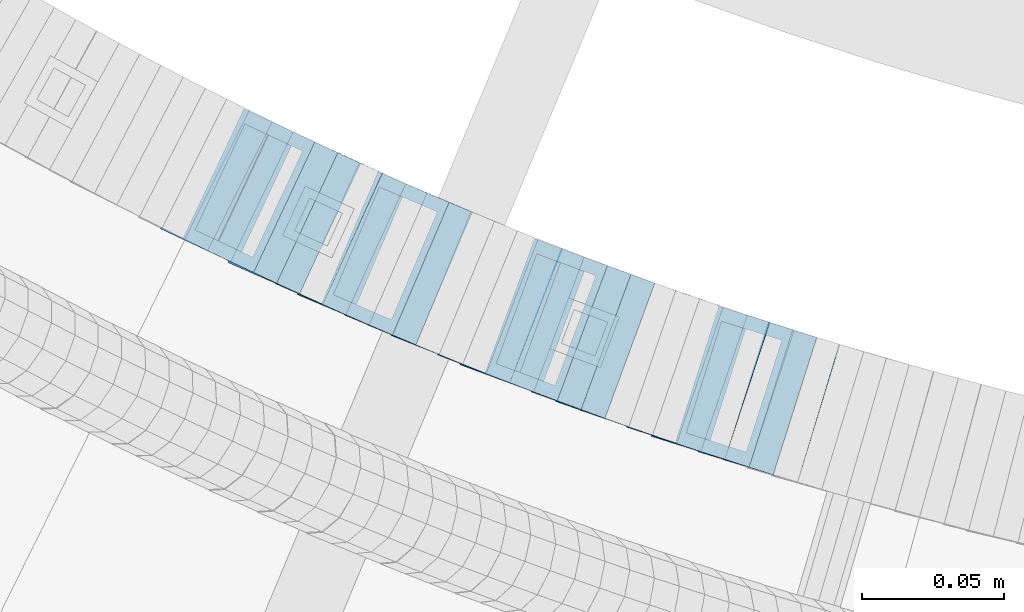
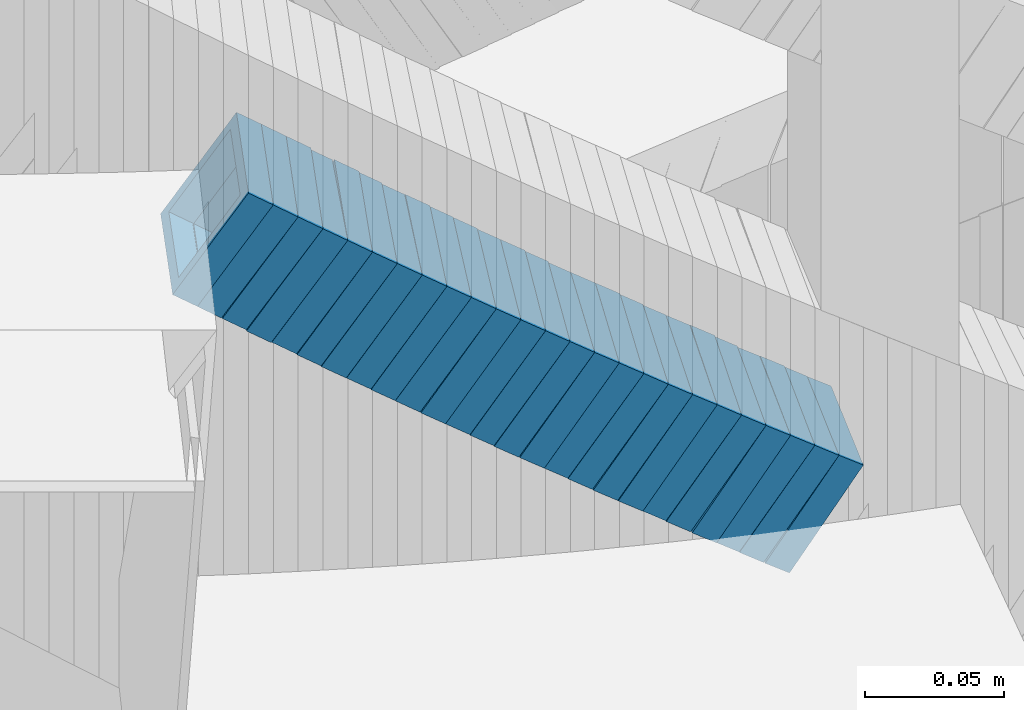
# One storey, part 695 of 975: 25 members.
"""IFC2X3 building model written with IfcOpenShell, lengths in millimetres."""

import ifcopenshell
import ifcopenshell.guid

model = None  # the IFC model being written
_history = None  # IfcOwnerHistory: only IFC2X3 demands one
_inside = {}  # id of a spatial element -> (the spatial element, [elements in it])
_under = {}  # id of a project, library or spatial element -> (it, [spatial elements below it])
_declared = {}  # id of a project -> (the project, [libraries it declares])
_typed = {}  # id of a type object -> (the type object, [elements of that type])
_made_of = {}  # id of a material, layer set ... -> (it, [elements and type objects made of it])


def new_model(schema):
    """Start an empty IFC model of exactly this schema.

    Asked for "IFC4X3", IfcOpenShell would pick the latest addendum, in which some entities
    have other attributes; the version numbers below select the first issue.
    IFC2X3 requires an IfcOwnerHistory on every rooted entity: one is made here for all.
    """
    global model, _history
    if schema == "IFC4X3":
        model = ifcopenshell.file(schema_version=(4, 3, 0, 0))
    else:
        model = ifcopenshell.file(schema=schema)
    _inside.clear()
    _under.clear()
    _declared.clear()
    _typed.clear()
    _made_of.clear()
    _history = None
    if model.schema == "IFC2X3":
        org = make("IfcOrganization", Name="unknown")
        user = make(
            "IfcPersonAndOrganization",
            ThePerson=make("IfcPerson", FamilyName="unknown"),
            TheOrganization=org,
        )
        app = make(
            "IfcApplication",
            ApplicationDeveloper=org,
            Version="unknown",
            ApplicationFullName="unknown",
            ApplicationIdentifier="unknown",
        )
        _history = make(
            "IfcOwnerHistory",
            OwningUser=user,
            OwningApplication=app,
            ChangeAction="ADDED",
            CreationDate=0,
        )
    return model


def make(cls, **values):
    """One entity of the class cls with the attributes given. An attribute that is None is left unset."""
    return model.create_entity(
        cls, **{name: value for name, value in values.items() if value is not None}
    )


def rooted(cls, **values):
    """An entity with a GlobalId (a new one), such as an element, a storey or a relation."""
    return make(cls, GlobalId=ifcopenshell.guid.new(), OwnerHistory=_history, **values)


def si_unit(unit_type, name, prefix=None):
    """IfcSIUnit, for example si_unit("LENGTHUNIT", "METRE", prefix="MILLI")."""
    return make("IfcSIUnit", UnitType=unit_type, Prefix=prefix, Name=name)


def assignment(units):
    """IfcUnitAssignment: the units of a project."""
    return None if units is None else make("IfcUnitAssignment", Units=units)


def point(xyz):
    """IfcCartesianPoint."""
    return None if xyz is None else make("IfcCartesianPoint", Coordinates=xyz)


def direction(xyz):
    """IfcDirection."""
    return None if xyz is None else make("IfcDirection", DirectionRatios=xyz)


def frame(location, z_axis=None, x_axis=None):
    """IfcAxis2Placement3D, a coordinate frame: its origin and axes. An axis left out is left unset."""
    return make(
        "IfcAxis2Placement3D",
        Location=point(location),
        Axis=direction(z_axis),
        RefDirection=direction(x_axis),
    )


def origin_with_axes():
    """The frame at (0, 0, 0) with the z axis (0, 0, 1) and the x axis (1, 0, 0) written out."""
    return frame((0.0, 0.0, 0.0), z_axis=(0.0, 0.0, 1.0), x_axis=(1.0, 0.0, 0.0))


def place(relative_to, where):
    """IfcLocalPlacement: puts the frame where relative to a parent placement (None: the world)."""
    return make(
        "IfcLocalPlacement", PlacementRelTo=relative_to, RelativePlacement=where
    )


def context(
    kind, dimensions, precision=None, world=None, true_north=None, identifier=None
):
    """IfcGeometricRepresentationContext, for example the 3D "Model" context."""
    return make(
        "IfcGeometricRepresentationContext",
        ContextIdentifier=identifier,
        ContextType=kind,
        CoordinateSpaceDimension=dimensions,
        Precision=precision,
        WorldCoordinateSystem=world,
        TrueNorth=true_north,
    )


def subcontext(parent, identifier, kind, view, scale=None):
    """IfcGeometricRepresentationSubContext, for example "Body" below "Model"."""
    return make(
        "IfcGeometricRepresentationSubContext",
        ContextIdentifier=identifier,
        ContextType=kind,
        ParentContext=parent,
        TargetScale=scale,
        TargetView=view,
    )


def project(units=None, contexts=None):
    """IfcProject with its units and contexts."""
    return rooted(
        "IfcProject",
        Name="project",
        RepresentationContexts=contexts,
        UnitsInContext=assignment(units),
    )


def spatial(cls, under=None, at=None, **own):
    """A site, building, storey or space (cls), placed at a placement, below another one or the project."""
    s = rooted(cls, ObjectPlacement=at, **own)
    if under is not None:
        _under.setdefault(under.id(), (under, []))[1].append(s)
    return s


def faces_of(points, faces, orient=None, outer=None):
    """IfcFace entities. A face is a list of loops; a loop is a list of indices into points, from 0.

    orient and outer hold one flag for each loop. By default every Orientation is true, the
    first loop of a face is its IfcFaceOuterBound and the others are IfcFaceBound.
    """
    made = []
    for i, loops in enumerate(faces):
        bounds = []
        for j, loop in enumerate(loops):
            is_outer = j == 0 if outer is None else outer[i][j]
            bounds.append(
                make(
                    "IfcFaceOuterBound" if is_outer else "IfcFaceBound",
                    Bound=make("IfcPolyLoop", Polygon=[points[k] for k in loop]),
                    Orientation=True if orient is None else orient[i][j],
                )
            )
        made.append(make("IfcFace", Bounds=bounds))
    return made


def faceted_brep(points, faces, orient=None, outer=None, voids=None):
    """IfcFacetedBrep: a solid bounded by flat faces; with voids (closed shells), ...WithVoids."""
    shared = [point(p) for p in points]
    hull = make("IfcClosedShell", CfsFaces=faces_of(shared, faces, orient, outer))
    if voids is None:
        return make("IfcFacetedBrep", Outer=hull)
    return make(
        "IfcFacetedBrepWithVoids",
        Outer=hull,
        Voids=[
            make(cls, CfsFaces=faces_of(shared, fs, o, b)) for cls, fs, o, b in voids
        ],
    )


def shape(context_of_items, identifier, shape_type, items):
    """IfcShapeRepresentation: the items that make up one representation, for example the "Body"."""
    return make(
        "IfcShapeRepresentation",
        ContextOfItems=context_of_items,
        RepresentationIdentifier=identifier,
        RepresentationType=shape_type,
        Items=items,
    )


def material(Name=None, Category=None):
    """IfcMaterial."""
    return make("IfcMaterial", Name=Name, Category=Category)


def made_of(thing, what):
    """Note that an element or type object is made of a material, layer set ...; save() writes the relation."""
    if what is not None:
        _made_of.setdefault(what.id(), (what, []))[1].append(thing)
    return thing


def type_object(cls, material=None, **own):
    """A type object (cls), such as IfcWallType, which elements share."""
    return made_of(rooted(cls, **own), material)


def element(
    cls,
    number,
    at=None,
    inside=None,
    cuts=None,
    type_object=None,
    material=None,
    context=None,
    identifier="Body",
    shape_type=None,
    held_by="IfcProductDefinitionShape",
    body=None,
    shapes=None,
    **own,
):
    """One element of the class cls, such as IfcWall. Its Tag is "e" and its number.

    at: its placement. inside: the storey or other place that contains it. cuts: it is an
    opening in that element (IfcRelVoidsElement). A single representation is given by context,
    identifier, shape_type and body (its items); several are given by shapes. held_by: the class
    of the entity that holds the representations. save() writes the other relations.
    """
    e = rooted(cls, Tag="e%d" % number, ObjectPlacement=at, **own)
    if body is not None:
        shapes = [shape(context, identifier, shape_type, body)]
    if shapes is not None:
        e.Representation = make(held_by, Representations=shapes)
    if inside is not None:
        _inside.setdefault(inside.id(), (inside, []))[1].append(e)
    if cuts is not None:
        rooted(
            "IfcRelVoidsElement", RelatingBuildingElement=cuts, RelatedOpeningElement=e
        )
    if type_object is not None:
        _typed.setdefault(type_object.id(), (type_object, []))[1].append(e)
    return made_of(e, material)


def aggregate(whole, parts):
    """IfcRelAggregates: a whole, such as a stair, and the parts it consists of."""
    return rooted("IfcRelAggregates", RelatingObject=whole, RelatedObjects=parts)


def save(model, path):
    """Write the relations noted so far, then the file.

    IfcRelAggregates (storeys below a building ...), IfcRelContainedInSpatialStructure (elements
    in a storey), IfcRelDefinesByType, IfcRelAssociatesMaterial and IfcRelDeclares: one each for
    every whole, place, type object, material and project.
    """
    for whole, parts in _under.values():
        aggregate(whole, parts)
    for where, things in _inside.values():
        rooted(
            "IfcRelContainedInSpatialStructure",
            RelatedElements=things,
            RelatingStructure=where,
        )
    for kind, things in _typed.values():
        rooted("IfcRelDefinesByType", RelatedObjects=things, RelatingType=kind)
    for what, things in _made_of.values():
        rooted("IfcRelAssociatesMaterial", RelatedObjects=things, RelatingMaterial=what)
    for by, libraries in _declared.values():
        rooted("IfcRelDeclares", RelatingContext=by, RelatedDefinitions=libraries)
    model.write(path)


model = new_model("IFC2X3")

# Units and contexts
model_context = context("Model", 3, precision=1e-05, world=origin_with_axes())
body_context = subcontext(model_context, "Body", "Model", "MODEL_VIEW")
ifc_project = project(units=[si_unit("LENGTHUNIT", "METRE", prefix="MILLI"), si_unit("AREAUNIT", "SQUARE_METRE"), si_unit("VOLUMEUNIT", "CUBIC_METRE"), si_unit("MASSUNIT", "GRAM", prefix="KILO"), si_unit("TIMEUNIT", "SECOND"), si_unit("PLANEANGLEUNIT", "RADIAN"), si_unit("SOLIDANGLEUNIT", "STERADIAN"), si_unit("THERMODYNAMICTEMPERATUREUNIT", "DEGREE_CELSIUS"), si_unit("LUMINOUSINTENSITYUNIT", "LUMEN")], contexts=[model_context])

# Site, building, storey
site_placement = place(None, origin_with_axes())
site = spatial("IfcSite", under=ifc_project, at=site_placement, CompositionType="ELEMENT")
building_placement = place(site_placement, origin_with_axes())
building = spatial("IfcBuilding", under=site, at=building_placement, Name="Undefined", CompositionType="ELEMENT")
storey_placement = place(building_placement, origin_with_axes())
storey = spatial("IfcBuildingStorey", under=building, at=storey_placement, Name="Undefined", CompositionType="ELEMENT", Elevation=0.0)

# Members
ifc_material = material()
member_type = type_object("IfcMemberType", Name="HSS2X2X.188_TUBES", PredefinedType="NOTDEFINED")
member_1_placement = place(storey_placement, frame((34126.8976479808, 2145.46557205936, 3695.1779549053), z_axis=(-0.424720211576408, -0.905324661035195, 3.22928826790303e-10), x_axis=(-0.76353959523756, 0.358203761111469, 0.537305641167168)))
element("IfcMember", 1, at=member_1_placement, inside=storey, type_object=member_type, material=ifc_material, Name="WALL", ObjectType="HSS2X2X.188_TUBES", context=body_context, shape_type="Brep", body=[
    faceted_brep([(0.0, 20.6374999999753, -20.6375000000298), (0.0, -20.6375000000153, -20.6375000000153), (10.6061303028146, -20.6374999999571, -20.6374999999643), (10.6061303027491, 20.6374999999971, -20.6375000000007), (0.0, -20.6374999999825, 20.6375000000335), (10.6061303027855, -20.6374999999825, 20.6375000000116), (0.0, 20.6375000000116, 20.6375000000189), (10.6061303027236, 20.637499999968, 20.6374999999716), (0.0, 25.3999999999724, -25.4000000000342), (0.0, 25.400000000016, 25.4000000000196), (10.6061303027163, 25.3999999999651, 25.3999999999651), (10.6061303027454, 25.3999999999942, -25.4000000000051), (0.0, -25.399999999976, 25.4000000000378), (10.6061303027891, -25.3999999999796, 25.4000000000124), (0.0, -25.400000000016, -25.4000000000196), (10.6061303028182, -25.3999999999505, -25.3999999999542)], [[[0, 1, 2, 3]], [[1, 4, 5, 2]], [[4, 6, 7, 5]], [[6, 0, 3, 7]], [[8, 9, 10, 11]], [[9, 12, 13, 10]], [[12, 14, 15, 13]], [[14, 8, 11, 15]], [[13, 15, 11, 10], [5, 7, 3, 2]], [[14, 12, 9, 8], [6, 4, 1, 0]]]),
])
member_2_placement = place(storey_placement, frame((34134.8446323784, 2141.73735715681, 3689.48657469151), z_axis=(-0.424720211576408, -0.905324661035195, 3.22928826790303e-10), x_axis=(-0.759668092710951, 0.356387499864383, 0.543959868793021)))
element("IfcMember", 2, at=member_2_placement, inside=storey, type_object=member_type, material=ifc_material, Name="WALL", ObjectType="HSS2X2X.188_TUBES", context=body_context, shape_type="Brep", body=[
    faceted_brep([(0.0, 20.6374999999753, -20.6375000000298), (0.0, -20.6375000000153, -20.6375000000153), (10.6625512894789, -20.6374999999625, -20.6374999999389), (10.6625512893879, 20.6374999999789, -20.6375000000371), (0.0, -20.6374999999825, 20.6375000000335), (10.6625512894352, -20.6374999999989, 20.6375000000153), (0.0, 20.6375000000116, 20.6375000000189), (10.6625512893443, 20.6374999999443, 20.6374999999134), (0.0, 25.3999999999724, -25.4000000000342), (0.0, 25.400000000016, 25.4000000000196), (10.6625512893297, 25.3999999999342, 25.3999999998996), (10.6625512893916, 25.399999999976, -25.4000000000415), (0.0, -25.399999999976, 25.4000000000378), (10.6625512894389, -25.399999999996, 25.400000000016), (0.0, -25.400000000016, -25.4000000000196), (10.6625512894971, -25.3999999999523, -25.3999999999214)], [[[0, 1, 2, 3]], [[1, 4, 5, 2]], [[4, 6, 7, 5]], [[6, 0, 3, 7]], [[8, 9, 10, 11]], [[9, 12, 13, 10]], [[12, 14, 15, 13]], [[14, 8, 11, 15]], [[13, 15, 11, 10], [5, 7, 3, 2]], [[14, 12, 9, 8], [6, 4, 1, 0]]]),
])
member_3_placement = place(storey_placement, frame((34143.0976479808, 2137.86557205936, 3683.6779549053), z_axis=(-0.424720211576408, -0.905324661035195, 3.22928826790303e-10), x_axis=(-0.76353959523756, 0.358203761111469, 0.537305641167168)))
element("IfcMember", 3, at=member_3_placement, inside=storey, type_object=member_type, material=ifc_material, Name="WALL", ObjectType="HSS2X2X.188_TUBES", context=body_context, shape_type="Brep", body=[
    faceted_brep([(0.0, 20.6374999999753, -20.6375000000298), (0.0, -20.6375000000153, -20.6375000000153), (10.6061303028146, -20.6374999999571, -20.6374999999643), (10.6061303027491, 20.6374999999971, -20.6375000000007), (0.0, -20.6374999999825, 20.6375000000335), (10.6061303027855, -20.6374999999825, 20.6375000000116), (0.0, 20.6375000000116, 20.6375000000189), (10.6061303027236, 20.637499999968, 20.6374999999716), (0.0, 25.3999999999724, -25.4000000000342), (0.0, 25.400000000016, 25.4000000000196), (10.6061303027163, 25.3999999999651, 25.3999999999651), (10.6061303027454, 25.3999999999942, -25.4000000000051), (0.0, -25.399999999976, 25.4000000000378), (10.6061303027891, -25.3999999999796, 25.4000000000124), (0.0, -25.400000000016, -25.4000000000196), (10.6061303028182, -25.3999999999505, -25.3999999999542)], [[[0, 1, 2, 3]], [[1, 4, 5, 2]], [[4, 6, 7, 5]], [[6, 0, 3, 7]], [[8, 9, 10, 11]], [[9, 12, 13, 10]], [[12, 14, 15, 13]], [[14, 8, 11, 15]], [[13, 15, 11, 10], [5, 7, 3, 2]], [[14, 12, 9, 8], [6, 4, 1, 0]]]),
])
member_4_placement = place(storey_placement, frame((34150.433045707, 2134.28175581554, 3677.98067466216), z_axis=(-0.401990062304751, -0.915644030072944, 1.61733169079525e-10), x_axis=(-0.768539881106551, 0.337407753046797, 0.543601379075367)))
element("IfcMember", 4, at=member_4_placement, inside=storey, type_object=member_type, material=ifc_material, Name="WALL", ObjectType="HSS2X2X.188_TUBES", context=body_context, shape_type="Brep", body=[
    faceted_brep([(0.0, 20.6374999999753, -20.6375000000298), (0.0, -20.6375000000153, -20.6375000000153), (10.6709887076922, -20.6374999999844, -20.6374999999825), (10.6709887076995, 20.6375000000171, -20.6374999999753), (0.0, -20.6374999999825, 20.6375000000335), (10.6709887076922, -20.6374999999971, 20.6375000000153), (0.0, 20.6375000000116, 20.6375000000189), (10.6709887076941, 20.6375000000025, 20.6375000000189), (0.0, 25.3999999999724, -25.4000000000342), (0.0, 25.400000000016, 25.4000000000196), (10.6709887076959, 25.3999999999996, 25.4000000000233), (10.6709887077013, 25.4000000000178, -25.3999999999724), (0.0, -25.399999999976, 25.4000000000378), (10.6709887076904, -25.3999999999978, 25.400000000016), (0.0, -25.400000000016, -25.4000000000196), (10.6709887076959, -25.3999999999796, -25.3999999999796)], [[[0, 1, 2, 3]], [[1, 4, 5, 2]], [[4, 6, 7, 5]], [[6, 0, 3, 7]], [[8, 9, 10, 11]], [[9, 12, 13, 10]], [[12, 14, 15, 13]], [[14, 8, 11, 15]], [[13, 15, 11, 10], [5, 7, 3, 2]], [[14, 12, 9, 8], [6, 4, 1, 0]]]),
])
member_5_placement = place(storey_placement, frame((34159.0634488441, 2130.56713730704, 3672.20714083712), z_axis=(-0.415494357820709, -0.909595755607488, 0.0), x_axis=(-0.766096610350828, 0.349945365160269, 0.539105022246887)))
element("IfcMember", 5, at=member_5_placement, inside=storey, type_object=member_type, material=ifc_material, Name="WALL", ObjectType="HSS2X2X.188_TUBES", context=body_context, shape_type="Brep", body=[
    faceted_brep([(0.0, 20.6374999999753, -20.6375000000298), (0.0, -20.6375000000153, -20.6375000000153), (10.5744976239494, -20.6375000000207, -20.6375000000335), (10.5744976239657, 20.6375000000098, -20.637500000008), (0.0, -20.6374999999825, 20.6375000000335), (10.5744976239639, -20.6375000000244, 20.6374999999753), (0.0, 20.6375000000116, 20.6375000000189), (10.5744976239803, 20.6374999999989, 20.6374999999935), (0.0, 25.3999999999724, -25.4000000000342), (0.0, 25.400000000016, 25.4000000000196), (10.5744976239857, 25.4000000000051, 25.4000000000015), (10.5744976239675, 25.4000000000124, -25.4000000000051), (0.0, -25.399999999976, 25.4000000000378), (10.5744976239639, -25.4000000000287, 25.3999999999724), (0.0, -25.400000000016, -25.4000000000196), (10.5744976239494, -25.4000000000215, -25.4000000000378)], [[[0, 1, 2, 3]], [[1, 4, 5, 2]], [[4, 6, 7, 5]], [[6, 0, 3, 7]], [[8, 9, 10, 11]], [[9, 12, 13, 10]], [[12, 14, 15, 13]], [[14, 8, 11, 15]], [[13, 15, 11, 10], [5, 7, 3, 2]], [[14, 12, 9, 8], [6, 4, 1, 0]]]),
])
member_6_placement = place(storey_placement, frame((34166.8877875413, 2126.91382037611, 3666.47216906364), z_axis=(-0.401990062304751, -0.915644030072944, 1.61733169079525e-10), x_axis=(-0.77245139699793, 0.339125003999077, 0.536947921998561)))
element("IfcMember", 6, at=member_6_placement, inside=storey, type_object=member_type, material=ifc_material, Name="WALL", ObjectType="HSS2X2X.188_TUBES", context=body_context, shape_type="Brep", body=[
    faceted_brep([(0.0, 20.6374999999753, -20.6375000000298), (0.0, -20.6375000000153, -20.6375000000153), (10.6216759506497, -20.637499999968, -20.6374999999534), (10.6216759506497, 20.6375000000262, -20.6374999999643), (0.0, -20.6374999999825, 20.6375000000335), (10.6216759506169, -20.6374999999935, 20.637500000008), (0.0, 20.6375000000116, 20.6375000000189), (10.6216759506242, 20.6375000000007, 20.6374999999971), (0.0, 25.3999999999724, -25.4000000000342), (0.0, 25.400000000016, 25.4000000000196), (10.6216759506169, 25.3999999999978, 25.3999999999869), (10.6216759506533, 25.4000000000269, -25.3999999999614), (0.0, -25.399999999976, 25.4000000000378), (10.6216759506242, -25.3999999999942, 25.4000000000051), (0.0, -25.400000000016, -25.4000000000196), (10.6216759506569, -25.3999999999614, -25.3999999999432)], [[[0, 1, 2, 3]], [[1, 4, 5, 2]], [[4, 6, 7, 5]], [[6, 0, 3, 7]], [[8, 9, 10, 11]], [[9, 12, 13, 10]], [[12, 14, 15, 13]], [[14, 8, 11, 15]], [[13, 15, 11, 10], [5, 7, 3, 2]], [[14, 12, 9, 8], [6, 4, 1, 0]]]),
])
member_7_placement = place(storey_placement, frame((34174.6641158069, 2123.42108280023, 3660.74408872126), z_axis=(-0.388553247249373, -0.921426271631088, 2.40247572946828e-10), x_axis=(-0.774720382129339, 0.326689318054537, 0.541370870090396)))
element("IfcMember", 7, at=member_7_placement, inside=storey, type_object=member_type, material=ifc_material, Name="WALL", ObjectType="HSS2X2X.188_TUBES", context=body_context, shape_type="Brep", body=[
    faceted_brep([(0.0, 20.6374999999753, -20.6375000000298), (0.0, -20.6375000000153, -20.6375000000153), (10.7093417165161, -20.637499999968, -20.6374999999534), (10.709341716436, 20.6374999999898, -20.6375000000116), (0.0, -20.6374999999825, 20.6375000000335), (10.7093417164688, -20.6374999999971, 20.6375000000153), (0.0, 20.6375000000116, 20.6375000000189), (10.7093417163924, 20.6374999999643, 20.6374999999571), (0.0, 25.3999999999724, -25.4000000000342), (0.0, 25.400000000016, 25.4000000000196), (10.7093417163815, 25.3999999999542, 25.3999999999469), (10.7093417164288, 25.3999999999869, -25.4000000000196), (0.0, -25.399999999976, 25.4000000000378), (10.7093417164724, -25.3999999999942, 25.4000000000196), (0.0, -25.400000000016, -25.4000000000196), (10.709341716527, -25.3999999999578, -25.3999999999432)], [[[0, 1, 2, 3]], [[1, 4, 5, 2]], [[4, 6, 7, 5]], [[6, 0, 3, 7]], [[8, 9, 10, 11]], [[9, 12, 13, 10]], [[12, 14, 15, 13]], [[14, 8, 11, 15]], [[13, 15, 11, 10], [5, 7, 3, 2]], [[14, 12, 9, 8], [6, 4, 1, 0]]]),
])
member_8_placement = place(storey_placement, frame((34183.0530458705, 2119.90586181394, 3654.99970631529), z_axis=(-0.392565197976837, -0.919724178945735, 0.0), x_axis=(-0.774896359918611, 0.330748445965264, 0.538647469943422)))
element("IfcMember", 8, at=member_8_placement, inside=storey, type_object=member_type, material=ifc_material, Name="WALL", ObjectType="HSS2X2X.188_TUBES", context=body_context, shape_type="Brep", body=[
    faceted_brep([(0.0, 20.6374999999753, -20.6375000000298), (0.0, -20.6375000000153, -20.6375000000153), (10.5806427026419, -20.6374999999607, -20.6374999999316), (10.5806427026473, 20.6375000000444, -20.6374999999207), (0.0, -20.6374999999825, 20.6375000000335), (10.5806427025509, -20.6375000000207, 20.6374999999643), (0.0, 20.6375000000116, 20.6375000000189), (10.5806427025545, 20.6374999999862, 20.6374999999716), (0.0, 25.3999999999724, -25.4000000000342), (0.0, 25.400000000016, 25.4000000000196), (10.5806427025436, 25.3999999999796, 25.3999999999614), (10.5806427026582, 25.4000000000542, -25.3999999999105), (0.0, -25.399999999976, 25.4000000000378), (10.5806427025418, -25.4000000000287, 25.3999999999542), (0.0, -25.400000000016, -25.4000000000196), (10.5806427026528, -25.3999999999542, -25.3999999999178)], [[[0, 1, 2, 3]], [[1, 4, 5, 2]], [[4, 6, 7, 5]], [[6, 0, 3, 7]], [[8, 9, 10, 11]], [[9, 12, 13, 10]], [[12, 14, 15, 13]], [[14, 8, 11, 15]], [[13, 15, 11, 10], [5, 7, 3, 2]], [[14, 12, 9, 8], [6, 4, 1, 0]]]),
])
member_9_placement = place(storey_placement, frame((34190.9163811091, 2116.4934750381, 3649.32683915835), z_axis=(-0.383015022804495, -0.923742113528485, 0.0), x_axis=(-0.77729483398558, 0.32229297999403, 0.540314700989985)))
element("IfcMember", 9, at=member_9_placement, inside=storey, type_object=member_type, material=ifc_material, Name="WALL", ObjectType="HSS2X2X.188_TUBES", context=body_context, shape_type="Brep", body=[
    faceted_brep([(0.0, 20.6374999999753, -20.6375000000298), (0.0, -20.6375000000153, -20.6375000000153), (10.5531985672587, -20.6374999999916, -20.6375000000007), (10.5531985672878, 20.6375000000062, -20.6374999999789), (0.0, -20.6374999999825, 20.6375000000335), (10.5531985672114, -20.6375000000353, 20.6374999999171), (0.0, 20.6375000000116, 20.6375000000189), (10.5531985672333, 20.6374999999607, 20.6374999999316), (0.0, 25.3999999999724, -25.4000000000342), (0.0, 25.400000000016, 25.4000000000196), (10.5531985672314, 25.399999999956, 25.3999999999251), (10.5531985672933, 25.4000000000106, -25.3999999999724), (0.0, -25.399999999976, 25.4000000000378), (10.5531985672023, -25.4000000000397, 25.3999999999069), (0.0, -25.400000000016, -25.4000000000196), (10.5531985672642, -25.3999999999851, -25.3999999999869)], [[[0, 1, 2, 3]], [[1, 4, 5, 2]], [[4, 6, 7, 5]], [[6, 0, 3, 7]], [[8, 9, 10, 11]], [[9, 12, 13, 10]], [[12, 14, 15, 13]], [[14, 8, 11, 15]], [[13, 15, 11, 10], [5, 7, 3, 2]], [[14, 12, 9, 8], [6, 4, 1, 0]]]),
])
member_10_placement = place(storey_placement, frame((34199.0305236889, 2113.10652839281, 3643.57087936196), z_axis=(-0.379066925164675, -0.925369259401996, 0.0), x_axis=(-0.777059549859998, 0.318313550942655, 0.54300546890216)))
element("IfcMember", 10, at=member_10_placement, inside=storey, type_object=member_type, material=ifc_material, Name="WALL", ObjectType="HSS2X2X.188_TUBES", context=body_context, shape_type="Brep", body=[
    faceted_brep([(0.0, 20.6374999999753, -20.6375000000298), (0.0, -20.6375000000153, -20.6375000000153), (10.6831643251735, -20.6375000000498, -20.6375000000953), (10.6831643252044, 20.637499999988, -20.6375000000226), (0.0, -20.6374999999825, 20.6375000000335), (10.6831643251935, -20.6375000000135, 20.637499999968), (0.0, 20.6375000000116, 20.6375000000189), (10.6831643252244, 20.6375000000226, 20.6375000000407), (0.0, 25.3999999999724, -25.4000000000342), (0.0, 25.400000000016, 25.4000000000196), (10.6831643252317, 25.4000000000306, 25.4000000000597), (10.6831643252044, 25.3999999999905, -25.4000000000196), (0.0, -25.399999999976, 25.4000000000378), (10.6831643251917, -25.400000000016, 25.3999999999614), (0.0, -25.400000000016, -25.4000000000196), (10.6831643251644, -25.400000000056, -25.4000000001179)], [[[0, 1, 2, 3]], [[1, 4, 5, 2]], [[4, 6, 7, 5]], [[6, 0, 3, 7]], [[8, 9, 10, 11]], [[9, 12, 13, 10]], [[12, 14, 15, 13]], [[14, 8, 11, 15]], [[13, 15, 11, 10], [5, 7, 3, 2]], [[14, 12, 9, 8], [6, 4, 1, 0]]]),
])
for number, where, z_axis, x_axis, name in (
    (11, (34207.1523084314, 2109.72508086677, 3637.78841234493), (-0.369459572873638, -0.929246804682173, 0.0), (-0.783332654127597, 0.31144551305074, 0.537951341087626), "WALL"),
    (12, (34215.4523084314, 2106.42508086677, 3632.08841234494), (-0.369459572873638, -0.929246804682173, 0.0), (-0.783332654127597, 0.31144551305074, 0.537951341087626), "WALL"),
):
    element("IfcMember", number, at=place(storey_placement, frame(where, z_axis=z_axis, x_axis=x_axis)), inside=storey, type_object=member_type, material=ifc_material, Name=name, ObjectType="HSS2X2X.188_TUBES", context=body_context, shape_type="Brep", body=[
        faceted_brep([(0.0, 20.6374999999753, -20.6375000000298), (0.0, -20.6375000000153, -20.6375000000153), (10.6004716875832, -20.6375000000153, -20.6375000000553), (10.6004716875814, 20.6374999999898, -20.6375000000444), (0.0, -20.6374999999825, 20.6375000000335), (10.6004716876068, -20.6375000000044, 20.6374999999862), (0.0, 20.6375000000116, 20.6375000000189), (10.6004716876032, 20.6374999999989, 20.6374999999971), (0.0, 25.3999999999724, -25.4000000000342), (0.0, 25.400000000016, 25.4000000000196), (10.600471687605, 25.4000000000015, 25.4000000000051), (10.6004716875814, 25.3999999999869, -25.4000000000487), (0.0, -25.399999999976, 25.4000000000378), (10.6004716876068, -25.4000000000015, 25.3999999999905), (0.0, -25.400000000016, -25.4000000000196), (10.6004716875814, -25.4000000000178, -25.4000000000669)], [[[0, 1, 2, 3]], [[1, 4, 5, 2]], [[4, 6, 7, 5]], [[6, 0, 3, 7]], [[8, 9, 10, 11]], [[9, 12, 13, 10]], [[12, 14, 15, 13]], [[14, 8, 11, 15]], [[13, 15, 11, 10], [5, 7, 3, 2]], [[14, 12, 9, 8], [6, 4, 1, 0]]]),
    ])
member_11_placement = place(storey_placement, frame((34223.4161244364, 2103.20320107185, 3626.41381643287), z_axis=(-0.35973226809311, -0.933055569241504, 0.0), x_axis=(-0.785610145271087, 0.302885839104528, 0.539515401186182)))
element("IfcMember", 13, at=member_11_placement, inside=storey, type_object=member_type, material=ifc_material, Name="WALL", ObjectType="HSS2X2X.188_TUBES", context=body_context, shape_type="Brep", body=[
    faceted_brep([(0.0, 20.6374999999753, -20.6375000000298), (0.0, -20.6375000000153, -20.6375000000153), (10.5744976239494, -20.6375000000207, -20.6375000000335), (10.5744976239657, 20.6375000000098, -20.637500000008), (0.0, -20.6374999999825, 20.6375000000335), (10.5744976239639, -20.6375000000244, 20.6374999999753), (0.0, 20.6375000000116, 20.6375000000189), (10.5744976239803, 20.6374999999989, 20.6374999999935), (0.0, 25.3999999999724, -25.4000000000342), (0.0, 25.400000000016, 25.4000000000196), (10.5744976239857, 25.4000000000051, 25.4000000000015), (10.5744976239675, 25.4000000000124, -25.4000000000051), (0.0, -25.399999999976, 25.4000000000378), (10.5744976239639, -25.4000000000287, 25.3999999999724), (0.0, -25.400000000016, -25.4000000000196), (10.5744976239494, -25.4000000000215, -25.4000000000378)], [[[0, 1, 2, 3]], [[1, 4, 5, 2]], [[4, 6, 7, 5]], [[6, 0, 3, 7]], [[8, 9, 10, 11]], [[9, 12, 13, 10]], [[12, 14, 15, 13]], [[14, 8, 11, 15]], [[13, 15, 11, 10], [5, 7, 3, 2]], [[14, 12, 9, 8], [6, 4, 1, 0]]]),
])
member_12_placement = place(storey_placement, frame((34231.3040696119, 2100.08409158801, 3620.68185329332), z_axis=(-0.346222869900943, -0.938152292731598, 0.0), x_axis=(-0.787388512015476, 0.290583856005715, 0.543673021010703)))
element("IfcMember", 14, at=member_12_placement, inside=storey, type_object=member_type, material=ifc_material, Name="WALL", ObjectType="HSS2X2X.188_TUBES", context=body_context, shape_type="Brep", body=[
    faceted_brep([(0.0, 20.6374999999753, -20.6375000000298), (0.0, -20.6375000000153, -20.6375000000153), (10.6709887076922, -20.6374999999844, -20.6374999999825), (10.6709887076995, 20.6375000000171, -20.6374999999753), (0.0, -20.6374999999825, 20.6375000000335), (10.6709887076922, -20.6374999999971, 20.6375000000153), (0.0, 20.6375000000116, 20.6375000000189), (10.6709887076941, 20.6375000000025, 20.6375000000189), (0.0, 25.3999999999724, -25.4000000000342), (0.0, 25.400000000016, 25.4000000000196), (10.6709887076959, 25.3999999999996, 25.4000000000233), (10.6709887077013, 25.4000000000178, -25.3999999999724), (0.0, -25.399999999976, 25.4000000000378), (10.6709887076904, -25.3999999999978, 25.400000000016), (0.0, -25.400000000016, -25.4000000000196), (10.6709887076959, -25.3999999999796, -25.3999999999796)], [[[0, 1, 2, 3]], [[1, 4, 5, 2]], [[4, 6, 7, 5]], [[6, 0, 3, 7]], [[8, 9, 10, 11]], [[9, 12, 13, 10]], [[12, 14, 15, 13]], [[14, 8, 11, 15]], [[13, 15, 11, 10], [5, 7, 3, 2]], [[14, 12, 9, 8], [6, 4, 1, 0]]]),
])
for number, where, z_axis, x_axis, name in (
    (15, (34239.8626189764, 2096.92557932256, 3614.87332487453), (-0.346222869900943, -0.938152292731598, 0.0), (-0.791397023826143, 0.292063186935838, 0.53701940888203), "WALL"),
    (16, (34248.2626189764, 2093.82557932257, 3609.17332487453), (-0.346222869900943, -0.938152292731598, 0.0), (-0.791397023826143, 0.292063186935838, 0.53701940888203), "WALL"),
):
    element("IfcMember", number, at=place(storey_placement, frame(where, z_axis=z_axis, x_axis=x_axis)), inside=storey, type_object=member_type, material=ifc_material, Name=name, ObjectType="HSS2X2X.188_TUBES", context=body_context, shape_type="Brep", body=[
        faceted_brep([(0.0, 20.6374999999753, -20.6375000000298), (0.0, -20.6375000000153, -20.6375000000153), (10.6061303028146, -20.6374999999571, -20.6374999999643), (10.6061303027491, 20.6374999999971, -20.6375000000007), (0.0, -20.6374999999825, 20.6375000000335), (10.6061303027855, -20.6374999999825, 20.6375000000116), (0.0, 20.6375000000116, 20.6375000000189), (10.6061303027236, 20.637499999968, 20.6374999999716), (0.0, 25.3999999999724, -25.4000000000342), (0.0, 25.400000000016, 25.4000000000196), (10.6061303027163, 25.3999999999651, 25.3999999999651), (10.6061303027454, 25.3999999999942, -25.4000000000051), (0.0, -25.399999999976, 25.4000000000378), (10.6061303027891, -25.3999999999796, 25.4000000000124), (0.0, -25.400000000016, -25.4000000000196), (10.6061303028182, -25.3999999999505, -25.3999999999542)], [[[0, 1, 2, 3]], [[1, 4, 5, 2]], [[4, 6, 7, 5]], [[6, 0, 3, 7]], [[8, 9, 10, 11]], [[9, 12, 13, 10]], [[12, 14, 15, 13]], [[14, 8, 11, 15]], [[13, 15, 11, 10], [5, 7, 3, 2]], [[14, 12, 9, 8], [6, 4, 1, 0]]]),
    ])
member_13_placement = place(storey_placement, frame((34256.1683907598, 2090.8512399513, 3603.50596859345), z_axis=(-0.336336397332263, -0.941741911475514, 3.18172624247381e-10), x_axis=(-0.789507159090244, 0.281966843032229, 0.545135896062339)))
element("IfcMember", 17, at=member_13_placement, inside=storey, type_object=member_type, material=ifc_material, Name="WALL", ObjectType="HSS2X2X.188_TUBES", context=body_context, shape_type="Brep", body=[
    faceted_brep([(0.0, 20.6374999999753, -20.6375000000298), (0.0, -20.6375000000153, -20.6375000000153), (10.6395488625676, -20.6374999999771, -20.6374999999716), (10.6395488625531, 20.6374999999916, -20.6375000000189), (0.0, -20.6374999999825, 20.6375000000335), (10.6395488625731, -20.6374999999844, 20.6375000000153), (0.0, 20.6375000000116, 20.6375000000189), (10.6395488625585, 20.6374999999825, 20.637499999968), (0.0, 25.3999999999724, -25.4000000000342), (0.0, 25.400000000016, 25.4000000000196), (10.6395488625567, 25.3999999999778, 25.3999999999614), (10.6395488625494, 25.3999999999887, -25.4000000000233), (0.0, -25.399999999976, 25.4000000000378), (10.6395488625749, -25.3999999999851, 25.400000000016), (0.0, -25.400000000016, -25.4000000000196), (10.6395488625658, -25.399999999976, -25.3999999999687)], [[[0, 1, 2, 3]], [[1, 4, 5, 2]], [[4, 6, 7, 5]], [[6, 0, 3, 7]], [[8, 9, 10, 11]], [[9, 12, 13, 10]], [[12, 14, 15, 13]], [[14, 8, 11, 15]], [[13, 15, 11, 10], [5, 7, 3, 2]], [[14, 12, 9, 8], [6, 4, 1, 0]]]),
])
member_14_placement = place(storey_placement, frame((34264.3914479799, 2087.85860074738, 3597.7201198608), z_axis=(-0.326337459514798, -0.945253332455077, -3.89439264836255e-10), x_axis=(-0.795645785952913, 0.274687234983759, 0.539902496968063)))
element("IfcMember", 18, at=member_14_placement, inside=storey, type_object=member_type, material=ifc_material, Name="WALL", ObjectType="HSS2X2X.188_TUBES", context=body_context, shape_type="Brep", body=[
    faceted_brep([(0.0, 20.6374999999753, -20.6375000000298), (0.0, -20.6375000000153, -20.6375000000153), (10.5550935571373, -20.6374999999935, -20.6374999999753), (10.5550935571373, 20.6375000000025, -20.6374999999862), (0.0, -20.6374999999825, 20.6375000000335), (10.5550935571027, -20.6374999999989, 20.6374999999862), (0.0, 20.6375000000116, 20.6375000000189), (10.5550935571027, 20.6374999999953, 20.6374999999716), (0.0, 25.3999999999724, -25.4000000000342), (0.0, 25.400000000016, 25.4000000000196), (10.5550935570991, 25.3999999999924, 25.3999999999651), (10.5550935571373, 25.3999999999996, -25.3999999999905), (0.0, -25.399999999976, 25.4000000000378), (10.5550935571009, -25.3999999999996, 25.3999999999833), (0.0, -25.400000000016, -25.4000000000196), (10.5550935571428, -25.3999999999905, -25.3999999999724)], [[[0, 1, 2, 3]], [[1, 4, 5, 2]], [[4, 6, 7, 5]], [[6, 0, 3, 7]], [[8, 9, 10, 11]], [[9, 12, 13, 10]], [[12, 14, 15, 13]], [[14, 8, 11, 15]], [[13, 15, 11, 10], [5, 7, 3, 2]], [[14, 12, 9, 8], [6, 4, 1, 0]]]),
])
member_15_placement = place(storey_placement, frame((34272.8852675777, 2084.90823668549, 3591.9545311128), z_axis=(-0.322900627911091, -0.946432873739402, 0.0), x_axis=(-0.799082549180622, 0.272628164061617, 0.535855357121109)))
element("IfcMember", 19, at=member_15_placement, inside=storey, type_object=member_type, material=ifc_material, Name="WALL", ObjectType="HSS2X2X.188_TUBES", context=body_context, shape_type="Brep", body=[
    faceted_brep([(0.0, 20.6374999999753, -20.6375000000298), (0.0, -20.6375000000153, -20.6375000000153), (10.6395488625676, -20.6374999999771, -20.6374999999716), (10.6395488625531, 20.6374999999916, -20.6375000000189), (0.0, -20.6374999999825, 20.6375000000335), (10.6395488625731, -20.6374999999844, 20.6375000000153), (0.0, 20.6375000000116, 20.6375000000189), (10.6395488625585, 20.6374999999825, 20.637499999968), (0.0, 25.3999999999724, -25.4000000000342), (0.0, 25.400000000016, 25.4000000000196), (10.6395488625567, 25.3999999999778, 25.3999999999614), (10.6395488625494, 25.3999999999887, -25.4000000000233), (0.0, -25.399999999976, 25.4000000000378), (10.6395488625749, -25.3999999999851, 25.400000000016), (0.0, -25.400000000016, -25.4000000000196), (10.6395488625658, -25.399999999976, -25.3999999999687)], [[[0, 1, 2, 3]], [[1, 4, 5, 2]], [[4, 6, 7, 5]], [[6, 0, 3, 7]], [[8, 9, 10, 11]], [[9, 12, 13, 10]], [[12, 14, 15, 13]], [[14, 8, 11, 15]], [[13, 15, 11, 10], [5, 7, 3, 2]], [[14, 12, 9, 8], [6, 4, 1, 0]]]),
])
member_16_placement = place(storey_placement, frame((34281.2914479799, 2082.05860074738, 3586.3201198608), z_axis=(-0.326337459514798, -0.945253332455077, -3.89439264836255e-10), x_axis=(-0.795645785952913, 0.274687234983759, 0.539902496968063)))
element("IfcMember", 20, at=member_16_placement, inside=storey, type_object=member_type, material=ifc_material, Name="WALL", ObjectType="HSS2X2X.188_TUBES", context=body_context, shape_type="Brep", body=[
    faceted_brep([(0.0, 20.6374999999753, -20.6375000000298), (0.0, -20.6375000000153, -20.6375000000153), (10.5550935571373, -20.6374999999935, -20.6374999999753), (10.5550935571373, 20.6375000000025, -20.6374999999862), (0.0, -20.6374999999825, 20.6375000000335), (10.5550935571027, -20.6374999999989, 20.6374999999862), (0.0, 20.6375000000116, 20.6375000000189), (10.5550935571027, 20.6374999999953, 20.6374999999716), (0.0, 25.3999999999724, -25.4000000000342), (0.0, 25.400000000016, 25.4000000000196), (10.5550935570991, 25.3999999999924, 25.3999999999651), (10.5550935571373, 25.3999999999996, -25.3999999999905), (0.0, -25.399999999976, 25.4000000000378), (10.5550935571009, -25.3999999999996, 25.3999999999833), (0.0, -25.400000000016, -25.4000000000196), (10.5550935571428, -25.3999999999905, -25.3999999999724)], [[[0, 1, 2, 3]], [[1, 4, 5, 2]], [[4, 6, 7, 5]], [[6, 0, 3, 7]], [[8, 9, 10, 11]], [[9, 12, 13, 10]], [[12, 14, 15, 13]], [[14, 8, 11, 15]], [[13, 15, 11, 10], [5, 7, 3, 2]], [[14, 12, 9, 8], [6, 4, 1, 0]]]),
])
for number, where, z_axis, x_axis, name in (
    (21, (34289.2916107478, 2079.22079986726, 3580.58499966883), (-0.312873575008118, -0.949794781024638, 0.0), (-0.797042365334196, 0.262555132110105, 0.543864202228014), "WALL"),
    (22, (34297.7214417144, 2076.37401516272, 3574.73213827413), (-0.299538105855776, -0.954084337540625, 0.0), (-0.80638388319023, 0.253167033059731, 0.534463737126083), "WALL"),
):
    element("IfcMember", number, at=place(storey_placement, frame(where, z_axis=z_axis, x_axis=x_axis)), inside=storey, type_object=member_type, material=ifc_material, Name=name, ObjectType="HSS2X2X.188_TUBES", context=body_context, shape_type="Brep", body=[
        faceted_brep([(0.0, 20.6374999999753, -20.6375000000298), (0.0, -20.6375000000153, -20.6375000000153), (10.6625512894789, -20.6374999999625, -20.6374999999389), (10.6625512893879, 20.6374999999789, -20.6375000000371), (0.0, -20.6374999999825, 20.6375000000335), (10.6625512894352, -20.6374999999989, 20.6375000000153), (0.0, 20.6375000000116, 20.6375000000189), (10.6625512893443, 20.6374999999443, 20.6374999999134), (0.0, 25.3999999999724, -25.4000000000342), (0.0, 25.400000000016, 25.4000000000196), (10.6625512893297, 25.3999999999342, 25.3999999998996), (10.6625512893916, 25.399999999976, -25.4000000000415), (0.0, -25.399999999976, 25.4000000000378), (10.6625512894389, -25.399999999996, 25.400000000016), (0.0, -25.400000000016, -25.4000000000196), (10.6625512894971, -25.3999999999523, -25.3999999999214)], [[[0, 1, 2, 3]], [[1, 4, 5, 2]], [[4, 6, 7, 5]], [[6, 0, 3, 7]], [[8, 9, 10, 11]], [[9, 12, 13, 10]], [[12, 14, 15, 13]], [[14, 8, 11, 15]], [[13, 15, 11, 10], [5, 7, 3, 2]], [[14, 12, 9, 8], [6, 4, 1, 0]]]),
    ])
member_17_placement = place(storey_placement, frame((34306.2181508846, 2073.72305013119, 3569.09775448157), z_axis=(-0.302740811284107, -0.953072925427556, -5.18799879500875e-10), x_axis=(-0.803066958789978, 0.25509185693328, 0.538527254859163)))
element("IfcMember", 23, at=member_17_placement, inside=storey, type_object=member_type, material=ifc_material, Name="WALL", ObjectType="HSS2X2X.188_TUBES", context=body_context, shape_type="Brep", body=[
    faceted_brep([(0.0, 20.6374999999753, -20.6375000000298), (0.0, -20.6375000000153, -20.6375000000153), (10.5806427026419, -20.6374999999607, -20.6374999999316), (10.5806427026473, 20.6375000000444, -20.6374999999207), (0.0, -20.6374999999825, 20.6375000000335), (10.5806427025509, -20.6375000000207, 20.6374999999643), (0.0, 20.6375000000116, 20.6375000000189), (10.5806427025545, 20.6374999999862, 20.6374999999716), (0.0, 25.3999999999724, -25.4000000000342), (0.0, 25.400000000016, 25.4000000000196), (10.5806427025436, 25.3999999999796, 25.3999999999614), (10.5806427026582, 25.4000000000542, -25.3999999999105), (0.0, -25.399999999976, 25.4000000000378), (10.5806427025418, -25.4000000000287, 25.3999999999542), (0.0, -25.400000000016, -25.4000000000196), (10.5806427026528, -25.3999999999542, -25.3999999999178)], [[[0, 1, 2, 3]], [[1, 4, 5, 2]], [[4, 6, 7, 5]], [[6, 0, 3, 7]], [[8, 9, 10, 11]], [[9, 12, 13, 10]], [[12, 14, 15, 13]], [[14, 8, 11, 15]], [[13, 15, 11, 10], [5, 7, 3, 2]], [[14, 12, 9, 8], [6, 4, 1, 0]]]),
])
member_18_placement = place(storey_placement, frame((34314.2216903628, 2071.12306264291, 3563.42795959015), z_axis=(-0.292504341929598, -0.956264194640965, 2.45950104726944e-11), x_axis=(-0.800853960868517, 0.244967093959789, 0.546465054910288)))
element("IfcMember", 24, at=member_18_placement, inside=storey, type_object=member_type, material=ifc_material, Name="WALL", ObjectType="HSS2X2X.188_TUBES", context=body_context, shape_type="Brep", body=[
    faceted_brep([(0.0, 20.6374999999753, -20.6375000000298), (0.0, -20.6375000000153, -20.6375000000153), (10.6061303028146, -20.6374999999571, -20.6374999999643), (10.6061303027491, 20.6374999999971, -20.6375000000007), (0.0, -20.6374999999825, 20.6375000000335), (10.6061303027855, -20.6374999999825, 20.6375000000116), (0.0, 20.6375000000116, 20.6375000000189), (10.6061303027236, 20.637499999968, 20.6374999999716), (0.0, 25.3999999999724, -25.4000000000342), (0.0, 25.400000000016, 25.4000000000196), (10.6061303027163, 25.3999999999651, 25.3999999999651), (10.6061303027454, 25.3999999999942, -25.4000000000051), (0.0, -25.399999999976, 25.4000000000378), (10.6061303027891, -25.3999999999796, 25.4000000000124), (0.0, -25.400000000016, -25.4000000000196), (10.6061303028182, -25.3999999999505, -25.3999999999542)], [[[0, 1, 2, 3]], [[1, 4, 5, 2]], [[4, 6, 7, 5]], [[6, 0, 3, 7]], [[8, 9, 10, 11]], [[9, 12, 13, 10]], [[12, 14, 15, 13]], [[14, 8, 11, 15]], [[13, 15, 11, 10], [5, 7, 3, 2]], [[14, 12, 9, 8], [6, 4, 1, 0]]]),
])
member_19_placement = place(storey_placement, frame((34322.9908339256, 2068.42485728502, 3557.5522421416), z_axis=(-0.289389501105856, -0.957211427350146, 0.0), x_axis=(-0.808269248899424, 0.244360470969592, 0.535713338933315)))
element("IfcMember", 25, at=member_19_placement, inside=storey, type_object=member_type, material=ifc_material, Name="WALL", ObjectType="HSS2X2X.188_TUBES", context=body_context, shape_type="Brep", body=[
    faceted_brep([(0.0, 20.6374999999753, -20.6375000000298), (0.0, -20.6375000000153, -20.6375000000153), (10.6395488625676, -20.6374999999771, -20.6374999999716), (10.6395488625531, 20.6374999999916, -20.6375000000189), (0.0, -20.6374999999825, 20.6375000000335), (10.6395488625731, -20.6374999999844, 20.6375000000153), (0.0, 20.6375000000116, 20.6375000000189), (10.6395488625585, 20.6374999999825, 20.637499999968), (0.0, 25.3999999999724, -25.4000000000342), (0.0, 25.400000000016, 25.4000000000196), (10.6395488625567, 25.3999999999778, 25.3999999999614), (10.6395488625494, 25.3999999999887, -25.4000000000233), (0.0, -25.399999999976, 25.4000000000378), (10.6395488625749, -25.3999999999851, 25.400000000016), (0.0, -25.400000000016, -25.4000000000196), (10.6395488625658, -25.399999999976, -25.3999999999687)], [[[0, 1, 2, 3]], [[1, 4, 5, 2]], [[4, 6, 7, 5]], [[6, 0, 3, 7]], [[8, 9, 10, 11]], [[9, 12, 13, 10]], [[12, 14, 15, 13]], [[14, 8, 11, 15]], [[13, 15, 11, 10], [5, 7, 3, 2]], [[14, 12, 9, 8], [6, 4, 1, 0]]]),
])

save(model, "model.ifc")
